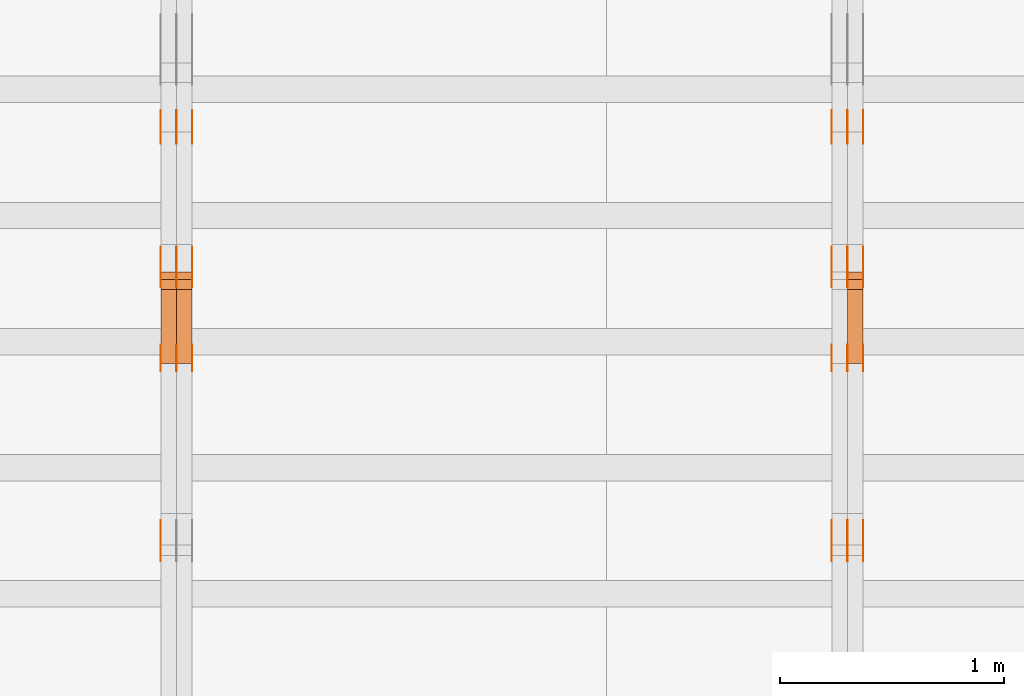
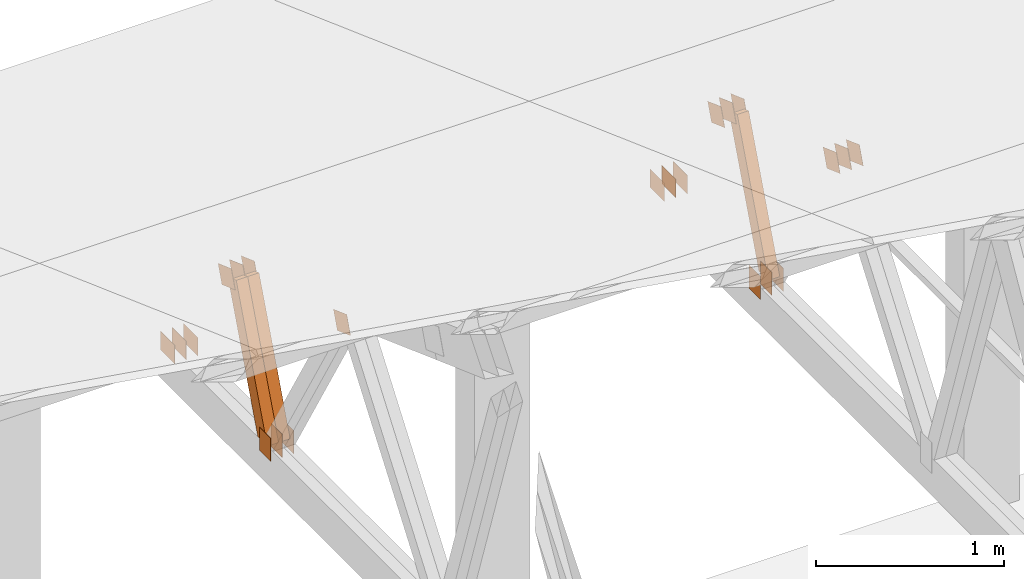
# One storey, part 169 of 189: 32 proxies.
"""IFC2X3 building model written with IfcOpenShell, lengths in millimetres."""

from ifc_helpers import new_model, entity, si_unit, converted_unit, derived_unit, direction, frame, frame_2d, origin, origin_2d_with_axis, place, context, subcontext, project, spatial, polyline, rectangle, outline, extrude, source, transform, mapped, material, type_object, type_shapes, element, save


model = new_model("IFC2X3")

# Units and contexts
model_context = context("Model", 3, precision=0.01, world=origin(), true_north=direction((6.12303176911189e-17, 1.0)))
body_context = subcontext(model_context, "Body", "Model", "MODEL_VIEW")
ifc_project = project(units=[si_unit("LENGTHUNIT", "METRE", prefix="MILLI"), si_unit("AREAUNIT", "SQUARE_METRE"), si_unit("VOLUMEUNIT", "CUBIC_METRE"), converted_unit("PLANEANGLEUNIT", "DEGREE", entity("IfcRatioMeasure", 0.0174532925199433), si_unit("PLANEANGLEUNIT", "RADIAN"), dimensions=[0, 0, 0, 0, 0, 0, 0]), si_unit("MASSUNIT", "GRAM", prefix="KILO"), derived_unit("MASSDENSITYUNIT", [(si_unit("MASSUNIT", "GRAM", prefix="KILO"), 1), (si_unit("LENGTHUNIT", "METRE"), -3)]), si_unit("TIMEUNIT", "SECOND"), si_unit("FREQUENCYUNIT", "HERTZ"), si_unit("THERMODYNAMICTEMPERATUREUNIT", "DEGREE_CELSIUS"), derived_unit("THERMALTRANSMITTANCEUNIT", [(si_unit("MASSUNIT", "GRAM", prefix="KILO"), 1), (si_unit("THERMODYNAMICTEMPERATUREUNIT", "KELVIN"), -1), (si_unit("TIMEUNIT", "SECOND"), -3)]), derived_unit("VOLUMETRICFLOWRATEUNIT", [(si_unit("LENGTHUNIT", "METRE"), 3), (si_unit("TIMEUNIT", "SECOND"), -1)]), si_unit("ELECTRICCURRENTUNIT", "AMPERE"), si_unit("ELECTRICVOLTAGEUNIT", "VOLT"), si_unit("POWERUNIT", "WATT"), si_unit("FORCEUNIT", "NEWTON"), si_unit("ILLUMINANCEUNIT", "LUX"), si_unit("LUMINOUSFLUXUNIT", "LUMEN"), si_unit("LUMINOUSINTENSITYUNIT", "CANDELA"), derived_unit("USERDEFINED", [(si_unit("MASSUNIT", "GRAM", prefix="KILO"), -1), (si_unit("LENGTHUNIT", "METRE"), -2), (si_unit("TIMEUNIT", "SECOND"), 3), (si_unit("LUMINOUSFLUXUNIT", "LUMEN"), 1)]), derived_unit("LINEARVELOCITYUNIT", [(si_unit("LENGTHUNIT", "METRE"), 1), (si_unit("TIMEUNIT", "SECOND"), -1)]), si_unit("PRESSUREUNIT", "PASCAL"), derived_unit("USERDEFINED", [(si_unit("LENGTHUNIT", "METRE"), -2), (si_unit("MASSUNIT", "GRAM", prefix="KILO"), 1), (si_unit("TIMEUNIT", "SECOND"), -2)])], contexts=[model_context])

# Site, building, storey
site_placement = place(None, origin())
site = spatial("IfcSite", under=ifc_project, at=site_placement, CompositionType="ELEMENT")
building_placement = place(site_placement, origin())
building = spatial("IfcBuilding", under=site, at=building_placement, CompositionType="ELEMENT")
storey_placement = place(building_placement, origin())
storey = spatial("IfcBuildingStorey", under=building, at=storey_placement, Name="Default", CompositionType="ELEMENT", Elevation=0.0)

# Proxies
ifc_material_1 = material(Name="IfcSurfaceStyle #231886")
building_element_proxy_type_1 = type_object("IfcBuildingElementProxyType", PredefinedType="NOTDEFINED", material=ifc_material_1)
shared_shape_1 = source(origin(), body_context, "Body", "SweptSolid", [
    extrude(outline(polyline([(-74.9999475298494, -60.0), (75.0000042257432, -60.0), (74.9999684051025, 60.0), (-75.0000251009963, 60.0), (-74.9999475298494, -60.0)])), frame((75.0000607644577, 60.0000865490217, 0.0), z_axis=(0.0, 0.0, 1.0), x_axis=(-1.0, 0.0, 0.0)), (0.0, 0.0, 1.0), 1.3),
])
type_shapes(building_element_proxy_type_1, [shared_shape_1])
proxy_1_placement = place(building_placement, frame((42301.3, 25732.0586805394, 1446.84420669249), z_axis=(-1.0, 0.0, 0.0), x_axis=(0.0, -0.939692620785908, 0.342020143325669)))
element("IfcBuildingElementProxy", 1, at=proxy_1_placement, inside=storey, type_object=building_element_proxy_type_1, material=ifc_material_1, context=body_context, shape_type="MappedRepresentation", body=[
    mapped(shared_shape_1, transform((0.0, 0.0, 0.0), scale=1.0)),
])
ifc_material_2 = material(Name="IfcSurfaceStyle #231829")
building_element_proxy_type_2 = type_object("IfcBuildingElementProxyType", PredefinedType="NOTDEFINED", material=ifc_material_2)
shared_shape_2 = source(origin(), body_context, "Body", "SweptSolid", [
    extrude(outline(polyline([(-74.9999475298494, -60.0), (75.0000042257432, -60.0), (74.9999684051025, 60.0), (-75.0000251009963, 60.0), (-74.9999475298494, -60.0)])), frame((75.0000607644577, 60.0000865490217, 0.0), z_axis=(0.0, 0.0, 1.0), x_axis=(-1.0, 0.0, 0.0)), (0.0, 0.0, 1.0), 1.29999999999999),
])
type_shapes(building_element_proxy_type_2, [shared_shape_2])
proxy_2_placement = place(building_placement, frame((42230.0, 25732.0586805394, 1446.84420669249), z_axis=(-1.0, 0.0, 0.0), x_axis=(0.0, -0.939692620785908, 0.342020143325669)))
element("IfcBuildingElementProxy", 2, at=proxy_2_placement, inside=storey, type_object=building_element_proxy_type_2, material=ifc_material_2, context=body_context, shape_type="MappedRepresentation", body=[
    mapped(shared_shape_2, transform((0.0, 0.0, 0.0), scale=1.0)),
])
ifc_material_3 = material(Name="IfcSurfaceStyle #231772")
building_element_proxy_type_3 = type_object("IfcBuildingElementProxyType", PredefinedType="NOTDEFINED", material=ifc_material_3)
shared_shape_3 = source(origin(), body_context, "Body", "SweptSolid", [
    extrude(outline(polyline([(-74.9999475298494, -60.0), (75.0000042257432, -60.0), (74.9999684051025, 60.0), (-75.0000251009963, 60.0), (-74.9999475298494, -60.0)])), frame((75.0000607644577, 60.0000865490217, 0.0), z_axis=(0.0, 0.0, 1.0), x_axis=(-1.0, 0.0, 0.0)), (0.0, 0.0, 1.0), 1.29999999999999),
])
type_shapes(building_element_proxy_type_3, [shared_shape_3])
proxy_3_placement = place(building_placement, frame((42231.3, 25732.0586805394, 1446.84420669249), z_axis=(-1.0, 0.0, 0.0), x_axis=(0.0, -0.939692620785908, 0.342020143325669)))
element("IfcBuildingElementProxy", 3, at=proxy_3_placement, inside=storey, type_object=building_element_proxy_type_3, material=ifc_material_3, context=body_context, shape_type="MappedRepresentation", body=[
    mapped(shared_shape_3, transform((0.0, 0.0, 0.0), scale=1.0)),
])
ifc_material_4 = material(Name="IfcSurfaceStyle #231715")
building_element_proxy_type_4 = type_object("IfcBuildingElementProxyType", PredefinedType="NOTDEFINED", material=ifc_material_4)
shared_shape_4 = source(origin(), body_context, "Body", "SweptSolid", [
    extrude(outline(polyline([(-74.9999475298494, -60.0), (75.0000042257432, -60.0), (74.9999684051025, 60.0), (-75.0000251009963, 60.0), (-74.9999475298494, -60.0)])), frame((75.0000607644577, 60.0000865490217, 0.0), z_axis=(0.0, 0.0, 1.0), x_axis=(-1.0, 0.0, 0.0)), (0.0, 0.0, 1.0), 1.29999999999999),
])
type_shapes(building_element_proxy_type_4, [shared_shape_4])
proxy_4_placement = place(building_placement, frame((42160.0, 25732.0586805394, 1446.84420669249), z_axis=(-1.0, 0.0, 0.0), x_axis=(0.0, -0.939692620785908, 0.342020143325669)))
element("IfcBuildingElementProxy", 4, at=proxy_4_placement, inside=storey, type_object=building_element_proxy_type_4, material=ifc_material_4, context=body_context, shape_type="MappedRepresentation", body=[
    mapped(shared_shape_4, transform((0.0, 0.0, 0.0), scale=1.0)),
])
ifc_material_5 = material(Name="IfcSurfaceStyle #231658")
building_element_proxy_type_5 = type_object("IfcBuildingElementProxyType", PredefinedType="NOTDEFINED", material=ifc_material_5)
shared_shape_5 = source(origin(), body_context, "Body", "SweptSolid", [
    extrude(rectangle(XDim=150.0, YDim=120.0, at=frame_2d((-7.105427357601e-15, 0.0), x_axis=(1.0, 0.0))), frame((75.0, 60.0, 0.0), z_axis=(0.0, 0.0, 1.0), x_axis=(-1.0, 0.0, 0.0)), (0.0, 0.0, 1.0), 1.3),
])
type_shapes(building_element_proxy_type_5, [shared_shape_5])
proxy_5_placement = place(building_placement, frame((42301.3, 26439.0083007813, 170.0), z_axis=(-1.0, 0.0, 0.0), x_axis=(0.0, 0.0, 1.0)))
element("IfcBuildingElementProxy", 5, at=proxy_5_placement, inside=storey, type_object=building_element_proxy_type_5, material=ifc_material_5, context=body_context, shape_type="MappedRepresentation", body=[
    mapped(shared_shape_5, transform((0.0, 0.0, 0.0), scale=1.0)),
])
ifc_material_6 = material(Name="IfcSurfaceStyle #231601")
building_element_proxy_type_6 = type_object("IfcBuildingElementProxyType", PredefinedType="NOTDEFINED", material=ifc_material_6)
shared_shape_6 = source(origin(), body_context, "Body", "SweptSolid", [
    extrude(rectangle(XDim=150.0, YDim=120.0, at=frame_2d((-7.105427357601e-15, 0.0), x_axis=(1.0, 0.0))), frame((75.0, 60.0, 0.0), z_axis=(0.0, 0.0, 1.0), x_axis=(-1.0, 0.0, 0.0)), (0.0, 0.0, 1.0), 1.29999999999999),
])
type_shapes(building_element_proxy_type_6, [shared_shape_6])
proxy_6_placement = place(building_placement, frame((42230.0, 26439.0083007813, 170.0), z_axis=(-1.0, 0.0, 0.0), x_axis=(0.0, 0.0, 1.0)))
element("IfcBuildingElementProxy", 6, at=proxy_6_placement, inside=storey, type_object=building_element_proxy_type_6, material=ifc_material_6, context=body_context, shape_type="MappedRepresentation", body=[
    mapped(shared_shape_6, transform((0.0, 0.0, 0.0), scale=1.0)),
])
ifc_material_7 = material(Name="IfcSurfaceStyle #231544")
building_element_proxy_type_7 = type_object("IfcBuildingElementProxyType", PredefinedType="NOTDEFINED", material=ifc_material_7)
shared_shape_7 = source(origin(), body_context, "Body", "SweptSolid", [
    extrude(rectangle(XDim=150.0, YDim=120.0, at=frame_2d((-7.105427357601e-15, 0.0), x_axis=(1.0, 0.0))), frame((75.0, 60.0, 0.0), z_axis=(0.0, 0.0, 1.0), x_axis=(-1.0, 0.0, 0.0)), (0.0, 0.0, 1.0), 1.29999999999999),
])
type_shapes(building_element_proxy_type_7, [shared_shape_7])
proxy_7_placement = place(building_placement, frame((42231.3, 26439.0083007813, 170.0), z_axis=(-1.0, 0.0, 0.0), x_axis=(0.0, 0.0, 1.0)))
element("IfcBuildingElementProxy", 7, at=proxy_7_placement, inside=storey, type_object=building_element_proxy_type_7, material=ifc_material_7, context=body_context, shape_type="MappedRepresentation", body=[
    mapped(shared_shape_7, transform((0.0, 0.0, 0.0), scale=1.0)),
])
ifc_material_8 = material(Name="IfcSurfaceStyle #231487")
building_element_proxy_type_8 = type_object("IfcBuildingElementProxyType", PredefinedType="NOTDEFINED", material=ifc_material_8)
shared_shape_8 = source(origin(), body_context, "Body", "SweptSolid", [
    extrude(rectangle(XDim=150.0, YDim=120.0, at=frame_2d((-7.105427357601e-15, 0.0), x_axis=(1.0, 0.0))), frame((75.0, 60.0, 0.0), z_axis=(0.0, 0.0, 1.0), x_axis=(-1.0, 0.0, 0.0)), (0.0, 0.0, 1.0), 1.29999999999999),
])
type_shapes(building_element_proxy_type_8, [shared_shape_8])
proxy_8_placement = place(building_placement, frame((42160.0, 26439.0083007813, 170.0), z_axis=(-1.0, 0.0, 0.0), x_axis=(0.0, 0.0, 1.0)))
element("IfcBuildingElementProxy", 8, at=proxy_8_placement, inside=storey, type_object=building_element_proxy_type_8, material=ifc_material_8, context=body_context, shape_type="MappedRepresentation", body=[
    mapped(shared_shape_8, transform((0.0, 0.0, 0.0), scale=1.0)),
])
ifc_material_9 = material(Name="IfcSurfaceStyle #230974")
building_element_proxy_type_9 = type_object("IfcBuildingElementProxyType", PredefinedType="NOTDEFINED", material=ifc_material_9)
shared_shape_9 = source(origin(), body_context, "Body", "SweptSolid", [
    extrude(outline(polyline([(-74.9999684051023, -60.0), (75.0000251009964, -60.0), (74.9999475298495, 60.0), (-75.0000042257435, 60.0), (-74.9999684051023, -60.0)])), frame((75.0000251009964, 60.0000006265238, 0.0), z_axis=(0.0, 0.0, 1.0), x_axis=(-1.0, 0.0, 0.0)), (0.0, 0.0, 1.0), 1.3),
])
type_shapes(building_element_proxy_type_9, [shared_shape_9])
proxy_9_placement = place(building_placement, frame((42301.3, 26956.490053282, 1001.18769055967), z_axis=(-1.0, 0.0, 0.0), x_axis=(0.0, -0.939692620785908, 0.342020143325669)))
element("IfcBuildingElementProxy", 9, at=proxy_9_placement, inside=storey, type_object=building_element_proxy_type_9, material=ifc_material_9, context=body_context, shape_type="MappedRepresentation", body=[
    mapped(shared_shape_9, transform((0.0, 0.0, 0.0), scale=1.0)),
])
ifc_material_10 = material(Name="IfcSurfaceStyle #230917")
building_element_proxy_type_10 = type_object("IfcBuildingElementProxyType", PredefinedType="NOTDEFINED", material=ifc_material_10)
shared_shape_10 = source(origin(), body_context, "Body", "SweptSolid", [
    extrude(outline(polyline([(-74.9999684051023, -60.0), (75.0000251009964, -60.0), (74.9999475298495, 60.0), (-75.0000042257435, 60.0), (-74.9999684051023, -60.0)])), frame((75.0000251009964, 60.0000006265238, 0.0), z_axis=(0.0, 0.0, 1.0), x_axis=(-1.0, 0.0, 0.0)), (0.0, 0.0, 1.0), 1.29999999999999),
])
type_shapes(building_element_proxy_type_10, [shared_shape_10])
proxy_10_placement = place(building_placement, frame((42230.0, 26956.490053282, 1001.18769055967), z_axis=(-1.0, 0.0, 0.0), x_axis=(0.0, -0.939692620785908, 0.342020143325669)))
element("IfcBuildingElementProxy", 10, at=proxy_10_placement, inside=storey, type_object=building_element_proxy_type_10, material=ifc_material_10, context=body_context, shape_type="MappedRepresentation", body=[
    mapped(shared_shape_10, transform((0.0, 0.0, 0.0), scale=1.0)),
])
ifc_material_11 = material(Name="IfcSurfaceStyle #230860")
building_element_proxy_type_11 = type_object("IfcBuildingElementProxyType", PredefinedType="NOTDEFINED", material=ifc_material_11)
shared_shape_11 = source(origin(), body_context, "Body", "SweptSolid", [
    extrude(outline(polyline([(-74.9999684051023, -60.0), (75.0000251009964, -60.0), (74.9999475298495, 60.0), (-75.0000042257435, 60.0), (-74.9999684051023, -60.0)])), frame((75.0000251009964, 60.0000006265238, 0.0), z_axis=(0.0, 0.0, 1.0), x_axis=(-1.0, 0.0, 0.0)), (0.0, 0.0, 1.0), 1.29999999999999),
])
type_shapes(building_element_proxy_type_11, [shared_shape_11])
proxy_11_placement = place(building_placement, frame((42231.3, 26956.490053282, 1001.18769055967), z_axis=(-1.0, 0.0, 0.0), x_axis=(0.0, -0.939692620785908, 0.342020143325669)))
element("IfcBuildingElementProxy", 11, at=proxy_11_placement, inside=storey, type_object=building_element_proxy_type_11, material=ifc_material_11, context=body_context, shape_type="MappedRepresentation", body=[
    mapped(shared_shape_11, transform((0.0, 0.0, 0.0), scale=1.0)),
])
ifc_material_12 = material(Name="IfcSurfaceStyle #230803")
building_element_proxy_type_12 = type_object("IfcBuildingElementProxyType", PredefinedType="NOTDEFINED", material=ifc_material_12)
shared_shape_12 = source(origin(), body_context, "Body", "SweptSolid", [
    extrude(outline(polyline([(-74.9999684051023, -60.0), (75.0000251009964, -60.0), (74.9999475298495, 60.0), (-75.0000042257435, 60.0), (-74.9999684051023, -60.0)])), frame((75.0000251009964, 60.0000006265238, 0.0), z_axis=(0.0, 0.0, 1.0), x_axis=(-1.0, 0.0, 0.0)), (0.0, 0.0, 1.0), 1.29999999999999),
])
type_shapes(building_element_proxy_type_12, [shared_shape_12])
proxy_12_placement = place(building_placement, frame((42160.0, 26956.490053282, 1001.18769055967), z_axis=(-1.0, 0.0, 0.0), x_axis=(0.0, -0.939692620785908, 0.342020143325669)))
element("IfcBuildingElementProxy", 12, at=proxy_12_placement, inside=storey, type_object=building_element_proxy_type_12, material=ifc_material_12, context=body_context, shape_type="MappedRepresentation", body=[
    mapped(shared_shape_12, transform((0.0, 0.0, 0.0), scale=1.0)),
])
ifc_material_13 = material(Name="IfcSurfaceStyle #230746")
building_element_proxy_type_13 = type_object("IfcBuildingElementProxyType", PredefinedType="NOTDEFINED", material=ifc_material_13)
shared_shape_13 = source(origin(), body_context, "Body", "SweptSolid", [
    extrude(rectangle(XDim=150.0, YDim=120.0, at=origin_2d_with_axis()), frame((75.0, 60.0, 0.0), z_axis=(0.0, 0.0, 1.0), x_axis=(-1.0, 0.0, 0.0)), (0.0, 0.0, 1.0), 1.3),
])
type_shapes(building_element_proxy_type_13, [shared_shape_13])
proxy_13_placement = place(building_placement, frame((42301.3, 27607.3129882813, 185.0), z_axis=(-1.0, 0.0, 0.0), x_axis=(0.0, -1.0, 0.0)))
element("IfcBuildingElementProxy", 13, at=proxy_13_placement, inside=storey, type_object=building_element_proxy_type_13, material=ifc_material_13, context=body_context, shape_type="MappedRepresentation", body=[
    mapped(shared_shape_13, transform((0.0, 0.0, 0.0), scale=1.0)),
])
ifc_material_14 = material(Name="IfcSurfaceStyle #230689")
building_element_proxy_type_14 = type_object("IfcBuildingElementProxyType", PredefinedType="NOTDEFINED", material=ifc_material_14)
shared_shape_14 = source(origin(), body_context, "Body", "SweptSolid", [
    extrude(rectangle(XDim=150.0, YDim=120.0, at=origin_2d_with_axis()), frame((75.0, 60.0, 0.0), z_axis=(0.0, 0.0, 1.0), x_axis=(-1.0, 0.0, 0.0)), (0.0, 0.0, 1.0), 1.29999999999999),
])
type_shapes(building_element_proxy_type_14, [shared_shape_14])
proxy_14_placement = place(building_placement, frame((42230.0, 27607.3129882813, 185.0), z_axis=(-1.0, 0.0, 0.0), x_axis=(0.0, -1.0, 0.0)))
element("IfcBuildingElementProxy", 14, at=proxy_14_placement, inside=storey, type_object=building_element_proxy_type_14, material=ifc_material_14, context=body_context, shape_type="MappedRepresentation", body=[
    mapped(shared_shape_14, transform((0.0, 0.0, 0.0), scale=1.0)),
])
ifc_material_15 = material(Name="IfcSurfaceStyle #230632")
building_element_proxy_type_15 = type_object("IfcBuildingElementProxyType", PredefinedType="NOTDEFINED", material=ifc_material_15)
shared_shape_15 = source(origin(), body_context, "Body", "SweptSolid", [
    extrude(rectangle(XDim=150.0, YDim=120.0, at=origin_2d_with_axis()), frame((75.0, 60.0, 0.0), z_axis=(0.0, 0.0, 1.0), x_axis=(-1.0, 0.0, 0.0)), (0.0, 0.0, 1.0), 1.29999999999999),
])
type_shapes(building_element_proxy_type_15, [shared_shape_15])
proxy_15_placement = place(building_placement, frame((42231.3, 27607.3129882813, 185.0), z_axis=(-1.0, 0.0, 0.0), x_axis=(0.0, -1.0, 0.0)))
element("IfcBuildingElementProxy", 15, at=proxy_15_placement, inside=storey, type_object=building_element_proxy_type_15, material=ifc_material_15, context=body_context, shape_type="MappedRepresentation", body=[
    mapped(shared_shape_15, transform((0.0, 0.0, 0.0), scale=1.0)),
])
ifc_material_16 = material(Name="IfcSurfaceStyle #230575")
building_element_proxy_type_16 = type_object("IfcBuildingElementProxyType", PredefinedType="NOTDEFINED", material=ifc_material_16)
shared_shape_16 = source(origin(), body_context, "Body", "SweptSolid", [
    extrude(rectangle(XDim=150.0, YDim=120.0, at=origin_2d_with_axis()), frame((75.0, 60.0, 0.0), z_axis=(0.0, 0.0, 1.0), x_axis=(-1.0, 0.0, 0.0)), (0.0, 0.0, 1.0), 1.29999999999999),
])
type_shapes(building_element_proxy_type_16, [shared_shape_16])
proxy_16_placement = place(building_placement, frame((42160.0, 27607.3129882813, 185.0), z_axis=(-1.0, 0.0, 0.0), x_axis=(0.0, -1.0, 0.0)))
element("IfcBuildingElementProxy", 16, at=proxy_16_placement, inside=storey, type_object=building_element_proxy_type_16, material=ifc_material_16, context=body_context, shape_type="MappedRepresentation", body=[
    mapped(shared_shape_16, transform((0.0, 0.0, 0.0), scale=1.0)),
])
ifc_material_17 = material(Name="IfcSurfaceStyle #223498")
building_element_proxy_type_17 = type_object("IfcBuildingElementProxyType", Name="T1-W14 223496", PredefinedType="NOTDEFINED", material=ifc_material_17)
shared_shape_17 = source(origin(), body_context, "Body", "SweptSolid", [
    extrude(outline(polyline([(-561.981237417233, -47.499947472121), (373.092610496013, -47.499947472121), (373.679602940405, -4.61719047935016e-05), (341.277449358876, 47.4999705580734), (-526.068425378061, 47.4999705580734), (-561.981237417233, -47.499947472121)])), frame((373.679632439416, 47.500120814091, 0.0), z_axis=(0.0, 0.0, 1.0), x_axis=(-1.0, 0.0, 0.0)), (0.0, 0.0, 1.0), 69.9999999999999),
])
type_shapes(building_element_proxy_type_17, [shared_shape_17])
proxy_17_placement = place(building_placement, frame((42300.0, 26895.4809555667, 1086.61918844835), z_axis=(-1.0, 0.0, 0.0), x_axis=(0.0, -0.353606472447933, -0.935394281916951)))
element("IfcBuildingElementProxy", 17, at=proxy_17_placement, inside=storey, type_object=building_element_proxy_type_17, material=ifc_material_17, Name="T1-W14", context=body_context, shape_type="MappedRepresentation", body=[
    mapped(shared_shape_17, transform((0.0, 0.0, 0.0), scale=1.0)),
])
ifc_material_18 = material(Name="IfcSurfaceStyle #215925")
building_element_proxy_type_18 = type_object("IfcBuildingElementProxyType", PredefinedType="NOTDEFINED", material=ifc_material_18)
shared_shape_18 = source(origin(), body_context, "Body", "SweptSolid", [
    extrude(outline(polyline([(-74.9999475298494, -60.0), (75.0000042257432, -60.0), (74.9999684051025, 60.0), (-75.0000251009963, 60.0), (-74.9999475298494, -60.0)])), frame((75.0000607644577, 60.0000865490217, 0.0), z_axis=(0.0, 0.0, 1.0), x_axis=(-1.0, 0.0, 0.0)), (0.0, 0.0, 1.0), 1.29999999999999),
])
type_shapes(building_element_proxy_type_18, [shared_shape_18])
proxy_18_placement = place(building_placement, frame((39160.0, 25732.0586805394, 1446.84420669249), z_axis=(-1.0, 0.0, 0.0), x_axis=(0.0, -0.939692620785908, 0.342020143325669)))
element("IfcBuildingElementProxy", 18, at=proxy_18_placement, inside=storey, type_object=building_element_proxy_type_18, material=ifc_material_18, context=body_context, shape_type="MappedRepresentation", body=[
    mapped(shared_shape_18, transform((0.0, 0.0, 0.0), scale=1.0)),
])
ifc_material_19 = material(Name="IfcSurfaceStyle #215868")
building_element_proxy_type_19 = type_object("IfcBuildingElementProxyType", PredefinedType="NOTDEFINED", material=ifc_material_19)
shared_shape_19 = source(origin(), body_context, "Body", "SweptSolid", [
    extrude(rectangle(XDim=150.0, YDim=120.0, at=frame_2d((-7.105427357601e-15, 0.0), x_axis=(1.0, 0.0))), frame((75.0, 60.0, 0.0), z_axis=(0.0, 0.0, 1.0), x_axis=(-1.0, 0.0, 0.0)), (0.0, 0.0, 1.0), 1.3),
])
type_shapes(building_element_proxy_type_19, [shared_shape_19])
proxy_19_placement = place(building_placement, frame((39301.3, 26439.0083007813, 170.0), z_axis=(-1.0, 0.0, 0.0), x_axis=(0.0, 0.0, 1.0)))
element("IfcBuildingElementProxy", 19, at=proxy_19_placement, inside=storey, type_object=building_element_proxy_type_19, material=ifc_material_19, context=body_context, shape_type="MappedRepresentation", body=[
    mapped(shared_shape_19, transform((0.0, 0.0, 0.0), scale=1.0)),
])
ifc_material_20 = material(Name="IfcSurfaceStyle #215811")
building_element_proxy_type_20 = type_object("IfcBuildingElementProxyType", PredefinedType="NOTDEFINED", material=ifc_material_20)
shared_shape_20 = source(origin(), body_context, "Body", "SweptSolid", [
    extrude(rectangle(XDim=150.0, YDim=120.0, at=frame_2d((-7.105427357601e-15, 0.0), x_axis=(1.0, 0.0))), frame((75.0, 60.0, 0.0), z_axis=(0.0, 0.0, 1.0), x_axis=(-1.0, 0.0, 0.0)), (0.0, 0.0, 1.0), 1.29999999999999),
])
type_shapes(building_element_proxy_type_20, [shared_shape_20])
proxy_20_placement = place(building_placement, frame((39230.0, 26439.0083007813, 170.0), z_axis=(-1.0, 0.0, 0.0), x_axis=(0.0, 0.0, 1.0)))
element("IfcBuildingElementProxy", 20, at=proxy_20_placement, inside=storey, type_object=building_element_proxy_type_20, material=ifc_material_20, context=body_context, shape_type="MappedRepresentation", body=[
    mapped(shared_shape_20, transform((0.0, 0.0, 0.0), scale=1.0)),
])
ifc_material_21 = material(Name="IfcSurfaceStyle #215754")
building_element_proxy_type_21 = type_object("IfcBuildingElementProxyType", PredefinedType="NOTDEFINED", material=ifc_material_21)
shared_shape_21 = source(origin(), body_context, "Body", "SweptSolid", [
    extrude(rectangle(XDim=150.0, YDim=120.0, at=frame_2d((-7.105427357601e-15, 0.0), x_axis=(1.0, 0.0))), frame((75.0, 60.0, 0.0), z_axis=(0.0, 0.0, 1.0), x_axis=(-1.0, 0.0, 0.0)), (0.0, 0.0, 1.0), 1.29999999999999),
])
type_shapes(building_element_proxy_type_21, [shared_shape_21])
proxy_21_placement = place(building_placement, frame((39231.3, 26439.0083007813, 170.0), z_axis=(-1.0, 0.0, 0.0), x_axis=(0.0, 0.0, 1.0)))
element("IfcBuildingElementProxy", 21, at=proxy_21_placement, inside=storey, type_object=building_element_proxy_type_21, material=ifc_material_21, context=body_context, shape_type="MappedRepresentation", body=[
    mapped(shared_shape_21, transform((0.0, 0.0, 0.0), scale=1.0)),
])
ifc_material_22 = material(Name="IfcSurfaceStyle #215697")
building_element_proxy_type_22 = type_object("IfcBuildingElementProxyType", PredefinedType="NOTDEFINED", material=ifc_material_22)
shared_shape_22 = source(origin(), body_context, "Body", "SweptSolid", [
    extrude(rectangle(XDim=150.0, YDim=120.0, at=frame_2d((-7.105427357601e-15, 0.0), x_axis=(1.0, 0.0))), frame((75.0, 60.0, 0.0), z_axis=(0.0, 0.0, 1.0), x_axis=(-1.0, 0.0, 0.0)), (0.0, 0.0, 1.0), 1.29999999999999),
])
type_shapes(building_element_proxy_type_22, [shared_shape_22])
proxy_22_placement = place(building_placement, frame((39160.0, 26439.0083007813, 170.0), z_axis=(-1.0, 0.0, 0.0), x_axis=(0.0, 0.0, 1.0)))
element("IfcBuildingElementProxy", 22, at=proxy_22_placement, inside=storey, type_object=building_element_proxy_type_22, material=ifc_material_22, context=body_context, shape_type="MappedRepresentation", body=[
    mapped(shared_shape_22, transform((0.0, 0.0, 0.0), scale=1.0)),
])
ifc_material_23 = material(Name="IfcSurfaceStyle #215184")
building_element_proxy_type_23 = type_object("IfcBuildingElementProxyType", PredefinedType="NOTDEFINED", material=ifc_material_23)
shared_shape_23 = source(origin(), body_context, "Body", "SweptSolid", [
    extrude(outline(polyline([(-74.9999684051023, -60.0), (75.0000251009964, -60.0), (74.9999475298495, 60.0), (-75.0000042257435, 60.0), (-74.9999684051023, -60.0)])), frame((75.0000251009964, 60.0000006265238, 0.0), z_axis=(0.0, 0.0, 1.0), x_axis=(-1.0, 0.0, 0.0)), (0.0, 0.0, 1.0), 1.3),
])
type_shapes(building_element_proxy_type_23, [shared_shape_23])
proxy_23_placement = place(building_placement, frame((39301.3, 26956.490053282, 1001.18769055967), z_axis=(-1.0, 0.0, 0.0), x_axis=(0.0, -0.939692620785908, 0.342020143325669)))
element("IfcBuildingElementProxy", 23, at=proxy_23_placement, inside=storey, type_object=building_element_proxy_type_23, material=ifc_material_23, context=body_context, shape_type="MappedRepresentation", body=[
    mapped(shared_shape_23, transform((0.0, 0.0, 0.0), scale=1.0)),
])
ifc_material_24 = material(Name="IfcSurfaceStyle #215127")
building_element_proxy_type_24 = type_object("IfcBuildingElementProxyType", PredefinedType="NOTDEFINED", material=ifc_material_24)
shared_shape_24 = source(origin(), body_context, "Body", "SweptSolid", [
    extrude(outline(polyline([(-74.9999684051023, -60.0), (75.0000251009964, -60.0), (74.9999475298495, 60.0), (-75.0000042257435, 60.0), (-74.9999684051023, -60.0)])), frame((75.0000251009964, 60.0000006265238, 0.0), z_axis=(0.0, 0.0, 1.0), x_axis=(-1.0, 0.0, 0.0)), (0.0, 0.0, 1.0), 1.29999999999999),
])
type_shapes(building_element_proxy_type_24, [shared_shape_24])
proxy_24_placement = place(building_placement, frame((39230.0, 26956.490053282, 1001.18769055967), z_axis=(-1.0, 0.0, 0.0), x_axis=(0.0, -0.939692620785908, 0.342020143325669)))
element("IfcBuildingElementProxy", 24, at=proxy_24_placement, inside=storey, type_object=building_element_proxy_type_24, material=ifc_material_24, context=body_context, shape_type="MappedRepresentation", body=[
    mapped(shared_shape_24, transform((0.0, 0.0, 0.0), scale=1.0)),
])
ifc_material_25 = material(Name="IfcSurfaceStyle #215070")
building_element_proxy_type_25 = type_object("IfcBuildingElementProxyType", PredefinedType="NOTDEFINED", material=ifc_material_25)
shared_shape_25 = source(origin(), body_context, "Body", "SweptSolid", [
    extrude(outline(polyline([(-74.9999684051023, -60.0), (75.0000251009964, -60.0), (74.9999475298495, 60.0), (-75.0000042257435, 60.0), (-74.9999684051023, -60.0)])), frame((75.0000251009964, 60.0000006265238, 0.0), z_axis=(0.0, 0.0, 1.0), x_axis=(-1.0, 0.0, 0.0)), (0.0, 0.0, 1.0), 1.29999999999999),
])
type_shapes(building_element_proxy_type_25, [shared_shape_25])
proxy_25_placement = place(building_placement, frame((39231.3, 26956.490053282, 1001.18769055967), z_axis=(-1.0, 0.0, 0.0), x_axis=(0.0, -0.939692620785908, 0.342020143325669)))
element("IfcBuildingElementProxy", 25, at=proxy_25_placement, inside=storey, type_object=building_element_proxy_type_25, material=ifc_material_25, context=body_context, shape_type="MappedRepresentation", body=[
    mapped(shared_shape_25, transform((0.0, 0.0, 0.0), scale=1.0)),
])
ifc_material_26 = material(Name="IfcSurfaceStyle #215013")
building_element_proxy_type_26 = type_object("IfcBuildingElementProxyType", PredefinedType="NOTDEFINED", material=ifc_material_26)
shared_shape_26 = source(origin(), body_context, "Body", "SweptSolid", [
    extrude(outline(polyline([(-74.9999684051023, -60.0), (75.0000251009964, -60.0), (74.9999475298495, 60.0), (-75.0000042257435, 60.0), (-74.9999684051023, -60.0)])), frame((75.0000251009964, 60.0000006265238, 0.0), z_axis=(0.0, 0.0, 1.0), x_axis=(-1.0, 0.0, 0.0)), (0.0, 0.0, 1.0), 1.29999999999999),
])
type_shapes(building_element_proxy_type_26, [shared_shape_26])
proxy_26_placement = place(building_placement, frame((39160.0, 26956.490053282, 1001.18769055967), z_axis=(-1.0, 0.0, 0.0), x_axis=(0.0, -0.939692620785908, 0.342020143325669)))
element("IfcBuildingElementProxy", 26, at=proxy_26_placement, inside=storey, type_object=building_element_proxy_type_26, material=ifc_material_26, context=body_context, shape_type="MappedRepresentation", body=[
    mapped(shared_shape_26, transform((0.0, 0.0, 0.0), scale=1.0)),
])
ifc_material_27 = material(Name="IfcSurfaceStyle #214956")
building_element_proxy_type_27 = type_object("IfcBuildingElementProxyType", PredefinedType="NOTDEFINED", material=ifc_material_27)
shared_shape_27 = source(origin(), body_context, "Body", "SweptSolid", [
    extrude(rectangle(XDim=150.0, YDim=120.0, at=origin_2d_with_axis()), frame((75.0, 60.0, 0.0), z_axis=(0.0, 0.0, 1.0), x_axis=(-1.0, 0.0, 0.0)), (0.0, 0.0, 1.0), 1.3),
])
type_shapes(building_element_proxy_type_27, [shared_shape_27])
proxy_27_placement = place(building_placement, frame((39301.3, 27607.3129882813, 185.0), z_axis=(-1.0, 0.0, 0.0), x_axis=(0.0, -1.0, 0.0)))
element("IfcBuildingElementProxy", 27, at=proxy_27_placement, inside=storey, type_object=building_element_proxy_type_27, material=ifc_material_27, context=body_context, shape_type="MappedRepresentation", body=[
    mapped(shared_shape_27, transform((0.0, 0.0, 0.0), scale=1.0)),
])
ifc_material_28 = material(Name="IfcSurfaceStyle #214899")
building_element_proxy_type_28 = type_object("IfcBuildingElementProxyType", PredefinedType="NOTDEFINED", material=ifc_material_28)
shared_shape_28 = source(origin(), body_context, "Body", "SweptSolid", [
    extrude(rectangle(XDim=150.0, YDim=120.0, at=origin_2d_with_axis()), frame((75.0, 60.0, 0.0), z_axis=(0.0, 0.0, 1.0), x_axis=(-1.0, 0.0, 0.0)), (0.0, 0.0, 1.0), 1.29999999999999),
])
type_shapes(building_element_proxy_type_28, [shared_shape_28])
proxy_28_placement = place(building_placement, frame((39230.0, 27607.3129882813, 185.0), z_axis=(-1.0, 0.0, 0.0), x_axis=(0.0, -1.0, 0.0)))
element("IfcBuildingElementProxy", 28, at=proxy_28_placement, inside=storey, type_object=building_element_proxy_type_28, material=ifc_material_28, context=body_context, shape_type="MappedRepresentation", body=[
    mapped(shared_shape_28, transform((0.0, 0.0, 0.0), scale=1.0)),
])
ifc_material_29 = material(Name="IfcSurfaceStyle #214842")
building_element_proxy_type_29 = type_object("IfcBuildingElementProxyType", PredefinedType="NOTDEFINED", material=ifc_material_29)
shared_shape_29 = source(origin(), body_context, "Body", "SweptSolid", [
    extrude(rectangle(XDim=150.0, YDim=120.0, at=origin_2d_with_axis()), frame((75.0, 60.0, 0.0), z_axis=(0.0, 0.0, 1.0), x_axis=(-1.0, 0.0, 0.0)), (0.0, 0.0, 1.0), 1.29999999999999),
])
type_shapes(building_element_proxy_type_29, [shared_shape_29])
proxy_29_placement = place(building_placement, frame((39231.3, 27607.3129882813, 185.0), z_axis=(-1.0, 0.0, 0.0), x_axis=(0.0, -1.0, 0.0)))
element("IfcBuildingElementProxy", 29, at=proxy_29_placement, inside=storey, type_object=building_element_proxy_type_29, material=ifc_material_29, context=body_context, shape_type="MappedRepresentation", body=[
    mapped(shared_shape_29, transform((0.0, 0.0, 0.0), scale=1.0)),
])
ifc_material_30 = material(Name="IfcSurfaceStyle #214785")
building_element_proxy_type_30 = type_object("IfcBuildingElementProxyType", PredefinedType="NOTDEFINED", material=ifc_material_30)
shared_shape_30 = source(origin(), body_context, "Body", "SweptSolid", [
    extrude(rectangle(XDim=150.0, YDim=120.0, at=origin_2d_with_axis()), frame((75.0, 60.0, 0.0), z_axis=(0.0, 0.0, 1.0), x_axis=(-1.0, 0.0, 0.0)), (0.0, 0.0, 1.0), 1.29999999999999),
])
type_shapes(building_element_proxy_type_30, [shared_shape_30])
proxy_30_placement = place(building_placement, frame((39160.0, 27607.3129882813, 185.0), z_axis=(-1.0, 0.0, 0.0), x_axis=(0.0, -1.0, 0.0)))
element("IfcBuildingElementProxy", 30, at=proxy_30_placement, inside=storey, type_object=building_element_proxy_type_30, material=ifc_material_30, context=body_context, shape_type="MappedRepresentation", body=[
    mapped(shared_shape_30, transform((0.0, 0.0, 0.0), scale=1.0)),
])
ifc_material_31 = material(Name="IfcSurfaceStyle #207708")
building_element_proxy_type_31 = type_object("IfcBuildingElementProxyType", Name="T1-W14 207706", PredefinedType="NOTDEFINED", material=ifc_material_31)
shared_shape_31 = source(origin(), body_context, "Body", "SweptSolid", [
    extrude(outline(polyline([(-561.981237417233, -47.499947472121), (373.092610496013, -47.499947472121), (373.679602940405, -4.61719047935016e-05), (341.277449358876, 47.4999705580734), (-526.068425378061, 47.4999705580734), (-561.981237417233, -47.499947472121)])), frame((373.679632439416, 47.500120814091, 0.0), z_axis=(0.0, 0.0, 1.0), x_axis=(-1.0, 0.0, 0.0)), (0.0, 0.0, 1.0), 69.9999999999999),
])
type_shapes(building_element_proxy_type_31, [shared_shape_31])
proxy_31_placement = place(building_placement, frame((39300.0, 26895.4809555667, 1086.61918844835), z_axis=(-1.0, 0.0, 0.0), x_axis=(0.0, -0.353606472447933, -0.935394281916951)))
element("IfcBuildingElementProxy", 31, at=proxy_31_placement, inside=storey, type_object=building_element_proxy_type_31, material=ifc_material_31, Name="T1-W14", context=body_context, shape_type="MappedRepresentation", body=[
    mapped(shared_shape_31, transform((0.0, 0.0, 0.0), scale=1.0)),
])
ifc_material_32 = material(Name="IfcSurfaceStyle #207642")
building_element_proxy_type_32 = type_object("IfcBuildingElementProxyType", Name="T1-W14 207640", PredefinedType="NOTDEFINED", material=ifc_material_32)
shared_shape_32 = source(origin(), body_context, "Body", "SweptSolid", [
    extrude(outline(polyline([(-561.981237417233, -47.499947472121), (373.092610496013, -47.499947472121), (373.679602940405, -4.61719047935016e-05), (341.277449358876, 47.4999705580734), (-526.068425378061, 47.4999705580734), (-561.981237417233, -47.499947472121)])), frame((373.679632439416, 47.500120814091, 0.0), z_axis=(0.0, 0.0, 1.0), x_axis=(-1.0, 0.0, 0.0)), (0.0, 0.0, 1.0), 69.9999999999999),
])
type_shapes(building_element_proxy_type_32, [shared_shape_32])
proxy_32_placement = place(building_placement, frame((39230.0, 26895.4809555667, 1086.61918844835), z_axis=(-1.0, 0.0, 0.0), x_axis=(0.0, -0.353606472447933, -0.935394281916951)))
element("IfcBuildingElementProxy", 32, at=proxy_32_placement, inside=storey, type_object=building_element_proxy_type_32, material=ifc_material_32, Name="T1-W14", context=body_context, shape_type="MappedRepresentation", body=[
    mapped(shared_shape_32, transform((0.0, 0.0, 0.0), scale=1.0)),
])

save(model, "model.ifc")
